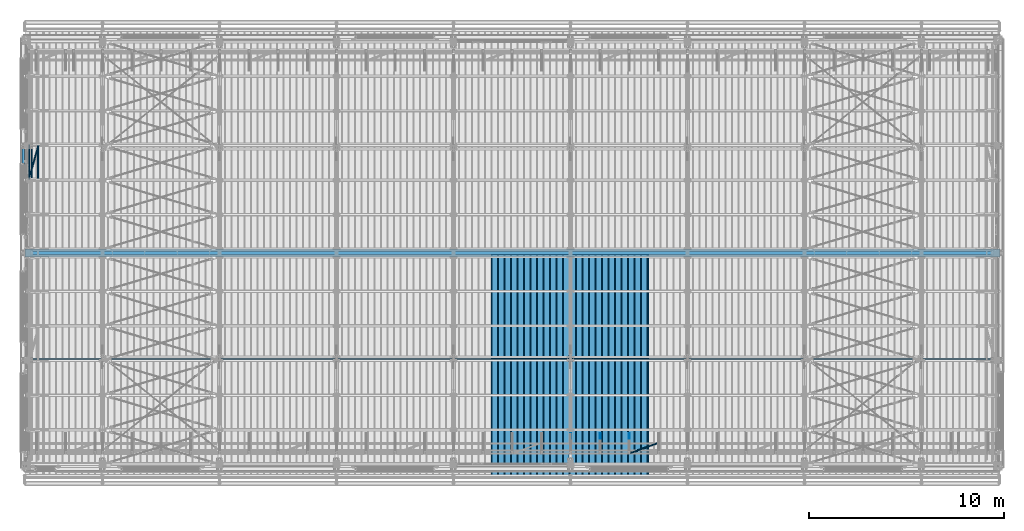
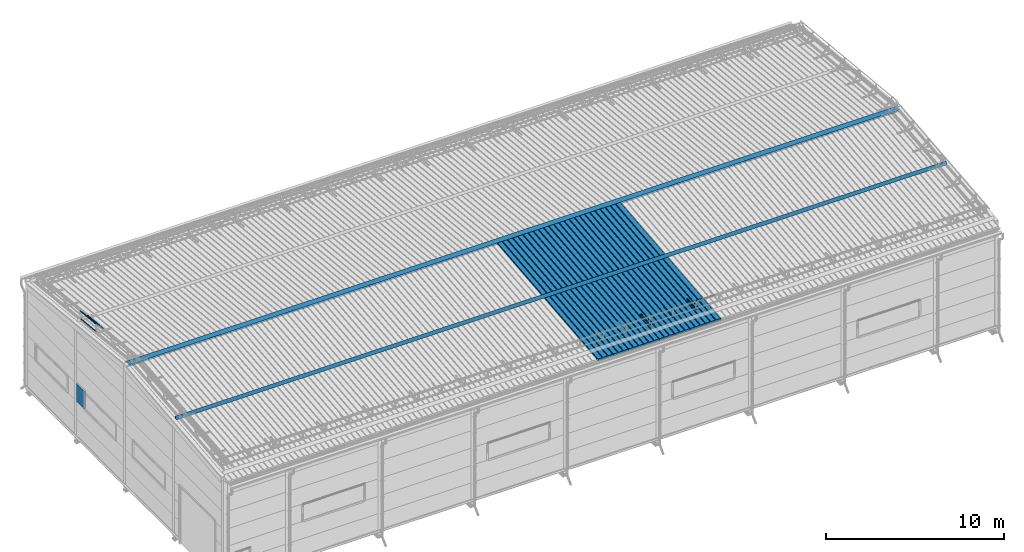
# One storey, part 46 of 709: 20 beams, 1 member, 21 elements without a shape of their own.
"""IFC4 building model written with IfcOpenShell, lengths in millimetres."""

from ifc_helpers import new_model, si_unit, direction, frame, origin_with_axes, place, context, subcontext, project, spatial, line, indexed_curve, outline, extrude, material, element, aggregate, save


model = new_model("IFC4")

# Units and contexts
model_context = context("Model", 3, precision=0.2, world=origin_with_axes(), true_north=direction((0.0, 1.0)))
body_context = subcontext(model_context, "Body", "Model", "MODEL_VIEW")
ifc_project = project(units=[si_unit("LENGTHUNIT", "METRE", prefix="MILLI"), si_unit("AREAUNIT", "SQUARE_METRE"), si_unit("VOLUMEUNIT", "CUBIC_METRE"), si_unit("MASSUNIT", "GRAM", prefix="KILO"), si_unit("TIMEUNIT", "SECOND"), si_unit("PLANEANGLEUNIT", "RADIAN"), si_unit("SOLIDANGLEUNIT", "STERADIAN"), si_unit("THERMODYNAMICTEMPERATUREUNIT", "DEGREE_CELSIUS"), si_unit("LUMINOUSINTENSITYUNIT", "LUMEN")], contexts=[model_context])

# Site, building, storey
site_placement = place(None, origin_with_axes())
site = spatial("IfcSite", under=ifc_project, at=site_placement, CompositionType="ELEMENT")
building_placement = place(site_placement, origin_with_axes())
building = spatial("IfcBuilding", under=site, at=building_placement, Name="Undefined", CompositionType="ELEMENT")
storey_placement = place(building_placement, origin_with_axes())
storey = spatial("IfcBuildingStorey", under=building, at=storey_placement, Name="Undefined", CompositionType="ELEMENT", Elevation=0.0)

# Assembly, beam
assembly_1_placement = place(storey_placement, frame((31452.44, -410.89541, 7279.78979), z_axis=(1.0, 0.0, 0.0), x_axis=(0.0, 0.9950371902, 0.099503719)))
assembly_1 = element("IfcElementAssembly", 1, at=assembly_1_placement, inside=storey)
ifc_material_1 = material(Name="Insulation", Category="Insulation")
beam_1_placement = place(assembly_1_placement, origin_with_axes())
beam_1 = element("IfcBeam", 2, at=beam_1_placement, material=ifc_material_1, ObjectType="P-99", context=body_context, shape_type="SolidModel", body=[
    extrude(outline(indexed_curve([(-509.8453, 89.5), (-490.1547, 89.5), (-471.67949, 57.5), (-471.67949, -88.5), (-436.67949, -88.5), (-436.67949, -91.5), (562.55841, -91.5), (562.55841, -89.5), (527.55841, -89.5), (527.55841, 57.5), (510.2379, 88.5), (489.7621, 88.5), (472.44159, 58.5), (196.71923, 58.5), (177.66667, 91.5), (155.66667, 91.5), (136.61411, 58.5), (-136.61411, 58.5), (-155.66667, 91.5), (-177.66667, 91.5), (-196.71923, 58.5), (-469.94744, 58.5), (-489.0, 91.5), (-511.0, 91.5), (-527.16581, 63.5), (-525.43376, 62.5)], segments=[line(1, 2, 3, 4, 5, 6, 7, 8, 9, 10, 11, 12, 13, 14, 15, 16, 17, 18, 19, 20, 21, 22, 23, 24, 25, 26, 1)])), frame((0.0, 0.0, 0.0), z_axis=(-1.0, 0.0, 0.0), x_axis=(0.0, 0.0, 1.0)), (0.0, 0.0, -1.0), 11459.0),
])
aggregate(assembly_1, [beam_1])

assembly_2_placement = place(storey_placement, frame((30452.44, -410.89541, 7279.78979), z_axis=(1.0, 0.0, 0.0), x_axis=(0.0, 0.9950371902, 0.099503719)))
assembly_2 = element("IfcElementAssembly", 3, at=assembly_2_placement, inside=storey)
beam_2_placement = place(assembly_2_placement, origin_with_axes())
beam_2 = element("IfcBeam", 4, at=beam_2_placement, material=ifc_material_1, ObjectType="P-99", context=body_context, shape_type="SolidModel", body=[
    extrude(outline(indexed_curve([(-509.8453, 89.5), (-490.1547, 89.5), (-471.67949, 57.5), (-471.67949, -88.5), (-436.67949, -88.5), (-436.67949, -91.5), (562.55841, -91.5), (562.55841, -89.5), (527.55841, -89.5), (527.55841, 57.5), (510.2379, 88.5), (489.7621, 88.5), (472.44159, 58.5), (196.71923, 58.5), (177.66667, 91.5), (155.66667, 91.5), (136.61411, 58.5), (-136.61411, 58.5), (-155.66667, 91.5), (-177.66667, 91.5), (-196.71923, 58.5), (-469.94744, 58.5), (-489.0, 91.5), (-511.0, 91.5), (-527.16581, 63.5), (-525.43376, 62.5)], segments=[line(1, 2, 3, 4, 5, 6, 7, 8, 9, 10, 11, 12, 13, 14, 15, 16, 17, 18, 19, 20, 21, 22, 23, 24, 25, 26, 1)])), frame((0.0, 0.0, 0.0), z_axis=(-1.0, 0.0, 0.0), x_axis=(0.0, 0.0, 1.0)), (0.0, 0.0, -1.0), 11459.0),
])
aggregate(assembly_2, [beam_2])

assembly_3_placement = place(storey_placement, frame((29452.44, -410.89541, 7279.78979), z_axis=(1.0, 0.0, 0.0), x_axis=(0.0, 0.9950371902, 0.099503719)))
assembly_3 = element("IfcElementAssembly", 5, at=assembly_3_placement, inside=storey)
beam_3_placement = place(assembly_3_placement, origin_with_axes())
beam_3 = element("IfcBeam", 6, at=beam_3_placement, material=ifc_material_1, ObjectType="P-99", context=body_context, shape_type="SolidModel", body=[
    extrude(outline(indexed_curve([(-509.8453, 89.5), (-490.1547, 89.5), (-471.67949, 57.5), (-471.67949, -88.5), (-436.67949, -88.5), (-436.67949, -91.5), (562.55841, -91.5), (562.55841, -89.5), (527.55841, -89.5), (527.55841, 57.5), (510.2379, 88.5), (489.7621, 88.5), (472.44159, 58.5), (196.71923, 58.5), (177.66667, 91.5), (155.66667, 91.5), (136.61411, 58.5), (-136.61411, 58.5), (-155.66667, 91.5), (-177.66667, 91.5), (-196.71923, 58.5), (-469.94744, 58.5), (-489.0, 91.5), (-511.0, 91.5), (-527.16581, 63.5), (-525.43376, 62.5)], segments=[line(1, 2, 3, 4, 5, 6, 7, 8, 9, 10, 11, 12, 13, 14, 15, 16, 17, 18, 19, 20, 21, 22, 23, 24, 25, 26, 1)])), frame((0.0, 0.0, 0.0), z_axis=(-1.0, 0.0, 0.0), x_axis=(0.0, 0.0, 1.0)), (0.0, 0.0, -1.0), 11459.0),
])
aggregate(assembly_3, [beam_3])

assembly_4_placement = place(storey_placement, frame((28452.44, -410.89541, 7279.78979), z_axis=(1.0, 0.0, 0.0), x_axis=(0.0, 0.9950371902, 0.099503719)))
assembly_4 = element("IfcElementAssembly", 7, at=assembly_4_placement, inside=storey)
beam_4_placement = place(assembly_4_placement, origin_with_axes())
beam_4 = element("IfcBeam", 8, at=beam_4_placement, material=ifc_material_1, ObjectType="P-99", context=body_context, shape_type="SolidModel", body=[
    extrude(outline(indexed_curve([(-509.8453, 89.5), (-490.1547, 89.5), (-471.67949, 57.5), (-471.67949, -88.5), (-436.67949, -88.5), (-436.67949, -91.5), (562.55841, -91.5), (562.55841, -89.5), (527.55841, -89.5), (527.55841, 57.5), (510.2379, 88.5), (489.7621, 88.5), (472.44159, 58.5), (196.71923, 58.5), (177.66667, 91.5), (155.66667, 91.5), (136.61411, 58.5), (-136.61411, 58.5), (-155.66667, 91.5), (-177.66667, 91.5), (-196.71923, 58.5), (-469.94744, 58.5), (-489.0, 91.5), (-511.0, 91.5), (-527.16581, 63.5), (-525.43376, 62.5)], segments=[line(1, 2, 3, 4, 5, 6, 7, 8, 9, 10, 11, 12, 13, 14, 15, 16, 17, 18, 19, 20, 21, 22, 23, 24, 25, 26, 1)])), frame((0.0, 0.0, 0.0), z_axis=(-1.0, 0.0, 0.0), x_axis=(0.0, 0.0, 1.0)), (0.0, 0.0, -1.0), 11459.0),
])
aggregate(assembly_4, [beam_4])

assembly_5_placement = place(storey_placement, frame((27452.44, -410.89541, 7279.78979), z_axis=(1.0, 0.0, 0.0), x_axis=(0.0, 0.9950371902, 0.099503719)))
assembly_5 = element("IfcElementAssembly", 9, at=assembly_5_placement, inside=storey)
beam_5_placement = place(assembly_5_placement, origin_with_axes())
beam_5 = element("IfcBeam", 10, at=beam_5_placement, material=ifc_material_1, ObjectType="P-99", context=body_context, shape_type="SolidModel", body=[
    extrude(outline(indexed_curve([(-509.8453, 89.5), (-490.1547, 89.5), (-471.67949, 57.5), (-471.67949, -88.5), (-436.67949, -88.5), (-436.67949, -91.5), (562.55841, -91.5), (562.55841, -89.5), (527.55841, -89.5), (527.55841, 57.5), (510.2379, 88.5), (489.7621, 88.5), (472.44159, 58.5), (196.71923, 58.5), (177.66667, 91.5), (155.66667, 91.5), (136.61411, 58.5), (-136.61411, 58.5), (-155.66667, 91.5), (-177.66667, 91.5), (-196.71923, 58.5), (-469.94744, 58.5), (-489.0, 91.5), (-511.0, 91.5), (-527.16581, 63.5), (-525.43376, 62.5)], segments=[line(1, 2, 3, 4, 5, 6, 7, 8, 9, 10, 11, 12, 13, 14, 15, 16, 17, 18, 19, 20, 21, 22, 23, 24, 25, 26, 1)])), frame((0.0, 0.0, 0.0), z_axis=(-1.0, 0.0, 0.0), x_axis=(0.0, 0.0, 1.0)), (0.0, 0.0, -1.0), 11459.0),
])
aggregate(assembly_5, [beam_5])

assembly_6_placement = place(storey_placement, frame((26452.44, -410.89541, 7279.78979), z_axis=(1.0, 0.0, 0.0), x_axis=(0.0, 0.9950371902, 0.099503719)))
assembly_6 = element("IfcElementAssembly", 11, at=assembly_6_placement, inside=storey)
beam_6_placement = place(assembly_6_placement, origin_with_axes())
beam_6 = element("IfcBeam", 12, at=beam_6_placement, material=ifc_material_1, ObjectType="P-99", context=body_context, shape_type="SolidModel", body=[
    extrude(outline(indexed_curve([(-509.8453, 89.5), (-490.1547, 89.5), (-471.67949, 57.5), (-471.67949, -88.5), (-436.67949, -88.5), (-436.67949, -91.5), (562.55841, -91.5), (562.55841, -89.5), (527.55841, -89.5), (527.55841, 57.5), (510.2379, 88.5), (489.7621, 88.5), (472.44159, 58.5), (196.71923, 58.5), (177.66667, 91.5), (155.66667, 91.5), (136.61411, 58.5), (-136.61411, 58.5), (-155.66667, 91.5), (-177.66667, 91.5), (-196.71923, 58.5), (-469.94744, 58.5), (-489.0, 91.5), (-511.0, 91.5), (-527.16581, 63.5), (-525.43376, 62.5)], segments=[line(1, 2, 3, 4, 5, 6, 7, 8, 9, 10, 11, 12, 13, 14, 15, 16, 17, 18, 19, 20, 21, 22, 23, 24, 25, 26, 1)])), frame((0.0, 0.0, 0.0), z_axis=(-1.0, 0.0, 0.0), x_axis=(0.0, 0.0, 1.0)), (0.0, 0.0, -1.0), 11459.0),
])
aggregate(assembly_6, [beam_6])

assembly_7_placement = place(storey_placement, frame((25452.44, -410.89541, 7279.78979), z_axis=(1.0, 0.0, 0.0), x_axis=(0.0, 0.9950371902, 0.099503719)))
assembly_7 = element("IfcElementAssembly", 13, at=assembly_7_placement, inside=storey)
beam_7_placement = place(assembly_7_placement, origin_with_axes())
beam_7 = element("IfcBeam", 14, at=beam_7_placement, material=ifc_material_1, ObjectType="P-99", context=body_context, shape_type="SolidModel", body=[
    extrude(outline(indexed_curve([(-509.8453, 89.5), (-490.1547, 89.5), (-471.67949, 57.5), (-471.67949, -88.5), (-436.67949, -88.5), (-436.67949, -91.5), (562.55841, -91.5), (562.55841, -89.5), (527.55841, -89.5), (527.55841, 57.5), (510.2379, 88.5), (489.7621, 88.5), (472.44159, 58.5), (196.71923, 58.5), (177.66667, 91.5), (155.66667, 91.5), (136.61411, 58.5), (-136.61411, 58.5), (-155.66667, 91.5), (-177.66667, 91.5), (-196.71923, 58.5), (-469.94744, 58.5), (-489.0, 91.5), (-511.0, 91.5), (-527.16581, 63.5), (-525.43376, 62.5)], segments=[line(1, 2, 3, 4, 5, 6, 7, 8, 9, 10, 11, 12, 13, 14, 15, 16, 17, 18, 19, 20, 21, 22, 23, 24, 25, 26, 1)])), frame((0.0, 0.0, 0.0), z_axis=(-1.0, 0.0, 0.0), x_axis=(0.0, 0.0, 1.0)), (0.0, 0.0, -1.0), 11459.0),
])
aggregate(assembly_7, [beam_7])

assembly_8_placement = place(storey_placement, frame((24452.44, -410.89541, 7279.78979), z_axis=(1.0, 0.0, 0.0), x_axis=(0.0, 0.9950371902, 0.099503719)))
assembly_8 = element("IfcElementAssembly", 15, at=assembly_8_placement, inside=storey)
beam_8_placement = place(assembly_8_placement, origin_with_axes())
beam_8 = element("IfcBeam", 16, at=beam_8_placement, material=ifc_material_1, ObjectType="P-99", context=body_context, shape_type="SolidModel", body=[
    extrude(outline(indexed_curve([(-509.8453, 89.5), (-490.1547, 89.5), (-471.67949, 57.5), (-471.67949, -88.5), (-436.67949, -88.5), (-436.67949, -91.5), (562.55841, -91.5), (562.55841, -89.5), (527.55841, -89.5), (527.55841, 57.5), (510.2379, 88.5), (489.7621, 88.5), (472.44159, 58.5), (196.71923, 58.5), (177.66667, 91.5), (155.66667, 91.5), (136.61411, 58.5), (-136.61411, 58.5), (-155.66667, 91.5), (-177.66667, 91.5), (-196.71923, 58.5), (-469.94744, 58.5), (-489.0, 91.5), (-511.0, 91.5), (-527.16581, 63.5), (-525.43376, 62.5)], segments=[line(1, 2, 3, 4, 5, 6, 7, 8, 9, 10, 11, 12, 13, 14, 15, 16, 17, 18, 19, 20, 21, 22, 23, 24, 25, 26, 1)])), frame((0.0, 0.0, 0.0), z_axis=(-1.0, 0.0, 0.0), x_axis=(0.0, 0.0, 1.0)), (0.0, 0.0, -1.0), 11459.0),
])
aggregate(assembly_8, [beam_8])

assembly_9_placement = place(storey_placement, frame((20.0, 11098.78127, 8522.53237), z_axis=(0.0, -0.119149147, -0.9928763673), x_axis=(1.0, 0.0, 0.0)))
assembly_9 = element("IfcElementAssembly", 17, at=assembly_9_placement, inside=storey)
ifc_material_2 = material(Name="Steel_Undefined", Category="STEEL")
beam_9_placement = place(assembly_9_placement, origin_with_axes())
beam_9 = element("IfcBeam", 18, at=beam_9_placement, material=ifc_material_2, context=body_context, shape_type="SolidModel", body=[
    extrude(outline(indexed_curve([(-1.0, -100.0), (1.0, -100.0), (1.0, 99.75443), (49.32497, 293.5753), (47.38438, 294.05915), (-1.0, 100.0)], segments=[line(1, 2, 3, 4, 5, 6, 1)])), frame((0.0, 0.0, 0.0), z_axis=(-1.0, 0.0, 0.0), x_axis=(0.0, 0.0, 1.0)), (0.0, 0.0, -1.0), 49995.0),
])
aggregate(assembly_9, [beam_9])

assembly_10_placement = place(storey_placement, frame((20.0, 11034.24431, 8305.67721), z_axis=(0.0, -0.119149147, -0.9928763673), x_axis=(1.0, 0.0, 0.0)))
assembly_10 = element("IfcElementAssembly", 19, at=assembly_10_placement, inside=storey)
beam_10_placement = place(assembly_10_placement, origin_with_axes())
beam_10 = element("IfcBeam", 20, at=beam_10_placement, material=ifc_material_2, context=body_context, shape_type="SolidModel", body=[
    extrude(outline(indexed_curve([(-1.0, -35.0), (1.0, -35.0), (1.0, 34.75443), (17.87512, 102.43686), (15.93453, 102.9207), (-1.0, 35.0)], segments=[line(1, 2, 3, 4, 5, 6, 1)])), frame((0.0, 0.0, 0.0), z_axis=(-1.0, 0.0, 0.0), x_axis=(0.0, 0.0, 1.0)), (0.0, 0.0, -1.0), 49995.0),
])
aggregate(assembly_10, [beam_10])

assembly_11_placement = place(storey_placement, frame((50015.0, 5573.74211, 8086.78846), z_axis=(0.0, -0.099503719, 0.9950371902), x_axis=(-1.0, 0.0, 0.0)))
assembly_11 = element("IfcElementAssembly", 21, at=assembly_11_placement, inside=storey)
beam_11_placement = place(assembly_11_placement, origin_with_axes())
beam_11 = element("IfcBeam", 22, at=beam_11_placement, material=ifc_material_2, context=body_context, shape_type="SolidModel", body=[
    extrude(outline(indexed_curve([(-100.0, -1.0), (100.0, -1.0), (-99.18584, 114.0), (-100.18584, 112.26795), (92.5359, 1.0), (-100.0, 1.0)], segments=[line(1, 2, 3, 4, 5, 6, 1)])), frame((0.0, 0.0, 0.0), z_axis=(-1.0, 0.0, 0.0), x_axis=(0.0, 0.0, 1.0)), (0.0, 0.0, -1.0), 49995.0),
])
aggregate(assembly_11, [beam_11])

assembly_12_placement = place(storey_placement, frame((28020.0, 768.92298, 7577.16191), z_axis=(0.0, -0.099503719, 0.9950371902), x_axis=(0.0, 0.9950371902, 0.099503719)))
assembly_12 = element("IfcElementAssembly", 23, at=assembly_12_placement, inside=storey)
beam_12_placement = place(assembly_12_placement, origin_with_axes())
beam_12 = element("IfcBeam", 24, at=beam_12_placement, material=ifc_material_2, ObjectType="601", context=body_context, shape_type="SolidModel", body=[
    extrude(outline(indexed_curve([(-20.0, -25.0), (20.0, -25.0), (20.0, -22.5), (-17.5, -22.5), (-17.5, 22.5), (20.0, 22.5), (20.0, 25.0), (-20.0, 25.0)], segments=[line(1, 2, 3, 4, 5, 6, 7, 8, 1)])), frame((0.0, 0.0, 0.0), z_axis=(-1.0, 0.0, 0.0), x_axis=(0.0, 0.0, 1.0)), (0.0, 0.0, -1.0), 1000.0),
])
aggregate(assembly_12, [beam_12])

assembly_13_placement = place(storey_placement, frame((29520.0, 768.92298, 7577.16191), z_axis=(0.0, -0.099503719, 0.9950371902), x_axis=(0.0, 0.9950371902, 0.099503719)))
assembly_13 = element("IfcElementAssembly", 25, at=assembly_13_placement, inside=storey)
beam_13_placement = place(assembly_13_placement, origin_with_axes())
beam_13 = element("IfcBeam", 26, at=beam_13_placement, material=ifc_material_2, ObjectType="601", context=body_context, shape_type="SolidModel", body=[
    extrude(outline(indexed_curve([(-20.0, -25.0), (20.0, -25.0), (20.0, -22.5), (-17.5, -22.5), (-17.5, 22.5), (20.0, 22.5), (20.0, 25.0), (-20.0, 25.0)], segments=[line(1, 2, 3, 4, 5, 6, 7, 8, 1)])), frame((0.0, 0.0, 0.0), z_axis=(-1.0, 0.0, 0.0), x_axis=(0.0, 0.0, 1.0)), (0.0, 0.0, -1.0), 1000.0),
])
aggregate(assembly_13, [beam_13])

assembly_14_placement = place(storey_placement, frame((31020.0, 768.92298, 7577.16191), z_axis=(0.0, -0.099503719, 0.9950371902), x_axis=(0.0, 0.9950371902, 0.099503719)))
assembly_14 = element("IfcElementAssembly", 27, at=assembly_14_placement, inside=storey)
beam_14_placement = place(assembly_14_placement, origin_with_axes())
beam_14 = element("IfcBeam", 28, at=beam_14_placement, material=ifc_material_2, ObjectType="601", context=body_context, shape_type="SolidModel", body=[
    extrude(outline(indexed_curve([(-20.0, -25.0), (20.0, -25.0), (20.0, -22.5), (-17.5, -22.5), (-17.5, 22.5), (20.0, 22.5), (20.0, 25.0), (-20.0, 25.0)], segments=[line(1, 2, 3, 4, 5, 6, 7, 8, 1)])), frame((0.0, 0.0, 0.0), z_axis=(-1.0, 0.0, 0.0), x_axis=(0.0, 0.0, 1.0)), (0.0, 0.0, -1.0), 1000.0),
])
aggregate(assembly_14, [beam_14])

assembly_15_placement = place(storey_placement, frame((31020.0, 723.87558, 8169.76263), z_axis=(0.0, 0.6332377902, 0.7739572992), x_axis=(0.9061831398, 0.3272952929, -0.2677870579)))
assembly_15 = element("IfcElementAssembly", 29, at=assembly_15_placement, inside=storey)
beam_15_placement = place(assembly_15_placement, origin_with_axes())
beam_15 = element("IfcBeam", 30, at=beam_15_placement, material=ifc_material_2, ObjectType="605", context=body_context, shape_type="SolidModel", body=[
    extrude(outline(indexed_curve([(-20.0, -25.0), (20.0, -25.0), (20.0, -22.5), (-17.5, -22.5), (-17.5, 22.5), (20.0, 22.5), (20.0, 25.0), (-20.0, 25.0)], segments=[line(1, 2, 3, 4, 5, 6, 7, 8, 1)])), frame((0.0, 0.0, 0.0), z_axis=(-1.0, 0.0, 0.0), x_axis=(0.0, 0.0, 1.0)), (0.0, 0.0, -1.0), 1655.29454),
])
aggregate(assembly_15, [beam_15])

assembly_16_placement = place(storey_placement, frame((240.0, 14831.17866, 8800.04453), z_axis=(1.0, 0.0, 0.0), x_axis=(0.0, 0.9950371902, -0.099503719)))
assembly_16 = element("IfcElementAssembly", 31, at=assembly_16_placement, inside=storey)
beam_16_placement = place(assembly_16_placement, origin_with_axes())
beam_16 = element("IfcBeam", 32, at=beam_16_placement, material=ifc_material_2, ObjectType="610", context=body_context, shape_type="SolidModel", body=[
    extrude(outline(indexed_curve([(-20.0, -25.0), (20.0, -25.0), (20.0, -22.5), (-17.5, -22.5), (-17.5, 22.5), (20.0, 22.5), (20.0, 25.0), (-20.0, 25.0)], segments=[line(1, 2, 3, 4, 5, 6, 7, 8, 1)])), frame((0.0, 0.0, 0.0), z_axis=(-1.0, 0.0, 0.0), x_axis=(0.0, 0.0, 1.0)), (0.0, 0.0, -1.0), 1782.14469),
])
aggregate(assembly_16, [beam_16])

assembly_17_placement = place(storey_placement, frame((240.0, 14781.4268, 8302.52594), z_axis=(1.0, 0.0, 0.0), x_axis=(0.0, 0.9950371902, -0.099503719)))
assembly_17 = element("IfcElementAssembly", 33, at=assembly_17_placement, inside=storey)
beam_17_placement = place(assembly_17_placement, origin_with_axes())
beam_17 = element("IfcBeam", 34, at=beam_17_placement, material=ifc_material_2, ObjectType="610", context=body_context, shape_type="SolidModel", body=[
    extrude(outline(indexed_curve([(-20.0, -25.0), (20.0, -25.0), (20.0, -22.5), (-17.5, -22.5), (-17.5, 22.5), (20.0, 22.5), (20.0, 25.0), (-20.0, 25.0)], segments=[line(1, 2, 3, 4, 5, 6, 7, 8, 1)])), frame((0.0, 0.0, 0.0), z_axis=(-1.0, 0.0, 0.0), x_axis=(0.0, 0.0, 1.0)), (0.0, 0.0, -1.0), 1782.14469),
])
aggregate(assembly_17, [beam_17])

assembly_18_placement = place(storey_placement, frame((375.56349, 14818.5139, 8673.39698), z_axis=(0.707106781, 0.070359754, 0.703597545), x_axis=(0.0, 0.9950371902, -0.099503719)))
assembly_18 = element("IfcElementAssembly", 35, at=assembly_18_placement, inside=storey)
beam_18_placement = place(assembly_18_placement, origin_with_axes())
beam_18 = element("IfcBeam", 36, at=beam_18_placement, material=ifc_material_2, ObjectType="610", context=body_context, shape_type="SolidModel", body=[
    extrude(outline(indexed_curve([(-20.0, -25.0), (20.0, -25.0), (20.0, -22.5), (-17.5, -22.5), (-17.5, 22.5), (20.0, 22.5), (20.0, 25.0), (-20.0, 25.0)], segments=[line(1, 2, 3, 4, 5, 6, 7, 8, 1)])), frame((0.0, 0.0, 0.0), z_axis=(-1.0, 0.0, 0.0), x_axis=(0.0, 0.0, 1.0)), (0.0, 0.0, -1.0), 1782.14469),
])
aggregate(assembly_18, [beam_18])

assembly_19_placement = place(storey_placement, frame((692.72078, 14786.95557, 8357.81368), z_axis=(0.707106781, 0.070359754, 0.703597545), x_axis=(0.0, 0.9950371902, -0.099503719)))
assembly_19 = element("IfcElementAssembly", 37, at=assembly_19_placement, inside=storey)
beam_19_placement = place(assembly_19_placement, origin_with_axes())
beam_19 = element("IfcBeam", 38, at=beam_19_placement, material=ifc_material_2, ObjectType="610", context=body_context, shape_type="SolidModel", body=[
    extrude(outline(indexed_curve([(-20.0, -25.0), (20.0, -25.0), (20.0, -22.5), (-17.5, -22.5), (-17.5, 22.5), (20.0, 22.5), (20.0, 25.0), (-20.0, 25.0)], segments=[line(1, 2, 3, 4, 5, 6, 7, 8, 1)])), frame((0.0, 0.0, 0.0), z_axis=(-1.0, 0.0, 0.0), x_axis=(0.0, 0.0, 1.0)), (0.0, 0.0, -1.0), 1782.14469),
])
aggregate(assembly_19, [beam_19])

# Assembly, member
assembly_20_placement = place(storey_placement, frame((234.14214, 14832.58585, 8814.11648), z_axis=(0.707106781, 0.070359754, 0.703597545), x_axis=(0.2585142331, 0.9004319084, -0.3498467802)))
assembly_20 = element("IfcElementAssembly", 39, at=assembly_20_placement, inside=storey)
member_placement = place(assembly_20_placement, origin_with_axes())
member = element("IfcMember", 40, at=member_placement, material=ifc_material_2, ObjectType="612", context=body_context, shape_type="SolidModel", body=[
    extrude(outline(indexed_curve([(-20.0, -25.0), (20.0, -25.0), (20.0, -22.5), (-17.5, -22.5), (-17.5, 22.5), (20.0, 22.5), (20.0, 25.0), (-20.0, 25.0)], segments=[line(1, 2, 3, 4, 5, 6, 7, 8, 1)])), frame((0.0, 0.0, 0.0), z_axis=(-1.0, 0.0, 0.0), x_axis=(0.0, 0.0, 1.0)), (0.0, 0.0, -1.0), 1914.6905),
])
aggregate(assembly_20, [member])

# Assembly, beam
assembly_21_placement = place(storey_placement, frame((-60.0, 15550.0, 3275.0), z_axis=(0.0, 0.0, -1.0), x_axis=(0.0, 1.0, 0.0)))
assembly_21 = element("IfcElementAssembly", 41, at=assembly_21_placement, inside=storey)
beam_20_placement = place(assembly_21_placement, origin_with_axes())
beam_20 = element("IfcBeam", 42, at=beam_20_placement, material=ifc_material_1, ObjectType="P-138", context=body_context, shape_type="SolidModel", body=[
    extrude(outline(indexed_curve([(-595.0, -60.0), (595.0, -60.0), (595.0, 60.0), (-595.0, 60.0)], segments=[line(1, 2, 3, 4, 1)])), frame((0.0, 0.0, 0.0), z_axis=(-1.0, 0.0, 0.0), x_axis=(0.0, 0.0, 1.0)), (0.0, 0.0, -1.0), 940.0),
])
aggregate(assembly_21, [beam_20])

save(model, "model.ifc")
